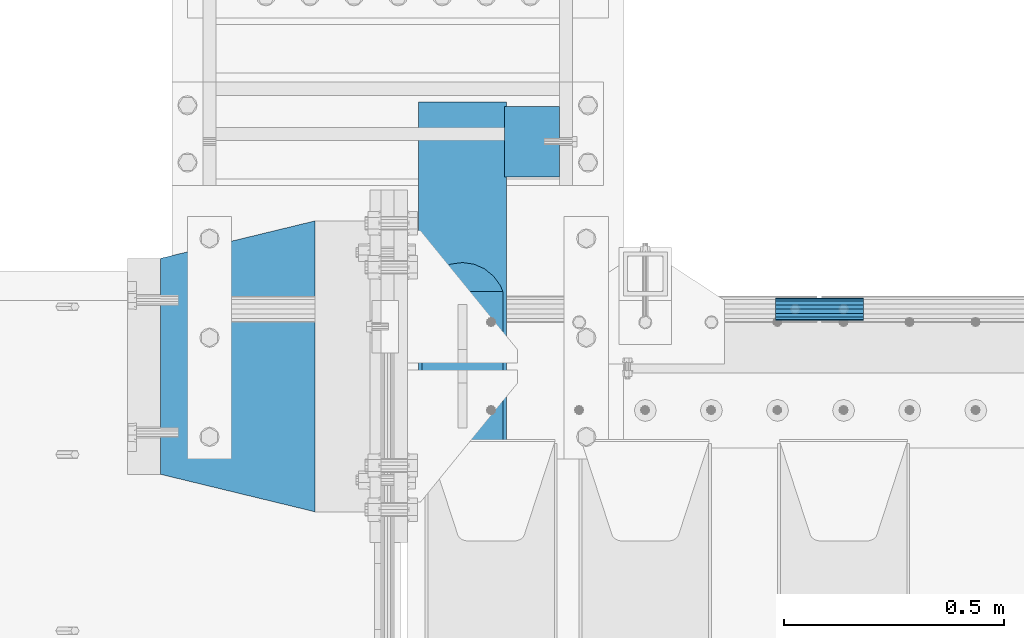
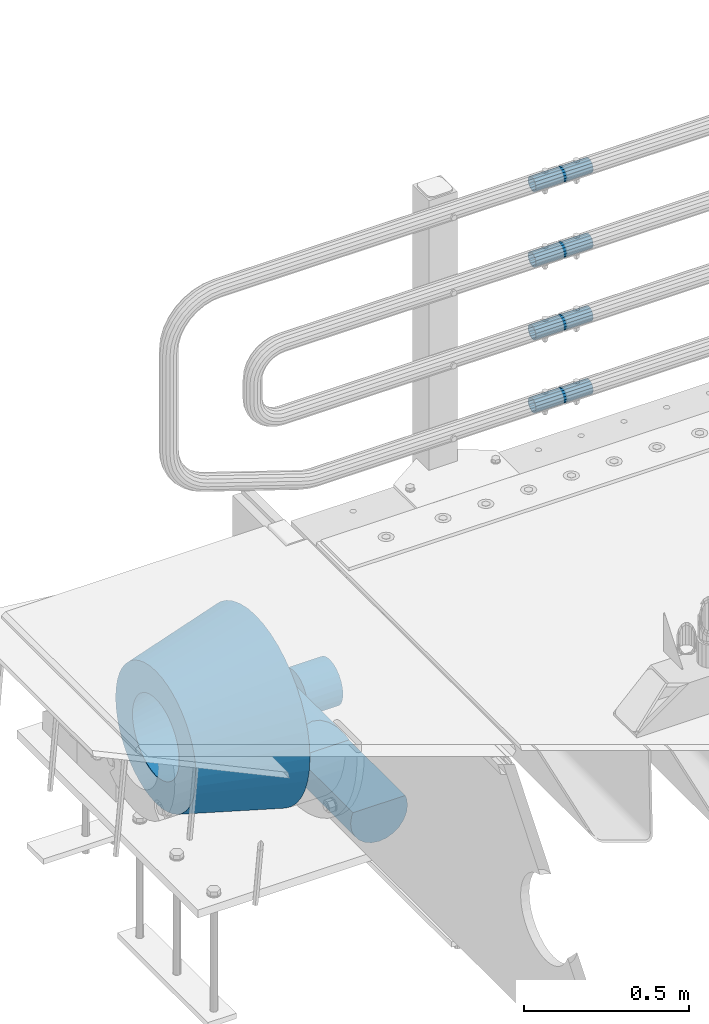
# One storey, part 146 of 242: 7 beams.
"""IFC2X3 building model written with IfcOpenShell, lengths in millimetres."""

from ifc_helpers import new_model, si_unit, frame, origin_with_axes, place, context, subcontext, project, spatial, faceted_brep, material, type_object, element, save


model = new_model("IFC2X3")

# Units and contexts
model_context = context("Model", 3, precision=1e-05, world=origin_with_axes())
body_context = subcontext(model_context, "Body", "Model", "MODEL_VIEW")
ifc_project = project(units=[si_unit("LENGTHUNIT", "METRE", prefix="MILLI"), si_unit("AREAUNIT", "SQUARE_METRE"), si_unit("VOLUMEUNIT", "CUBIC_METRE"), si_unit("MASSUNIT", "GRAM", prefix="KILO"), si_unit("TIMEUNIT", "SECOND"), si_unit("PLANEANGLEUNIT", "RADIAN"), si_unit("SOLIDANGLEUNIT", "STERADIAN"), si_unit("THERMODYNAMICTEMPERATUREUNIT", "DEGREE_CELSIUS"), si_unit("LUMINOUSINTENSITYUNIT", "LUMEN")], contexts=[model_context])

# Site, building, storey
site_placement = place(None, origin_with_axes())
site = spatial("IfcSite", under=ifc_project, at=site_placement, CompositionType="ELEMENT")
building_placement = place(site_placement, origin_with_axes())
building = spatial("IfcBuilding", under=site, at=building_placement, Name="Standard", CompositionType="ELEMENT")
storey_placement = place(building_placement, origin_with_axes())
storey = spatial("IfcBuildingStorey", under=building, at=storey_placement, Name="Undefined", CompositionType="ELEMENT", Elevation=0.0)

# Beams
ifc_material_1 = material()
beam_type_1 = type_object("IfcBeamType", PredefinedType="NOTDEFINED")
beam_1_placement = place(storey_placement, frame((-41605.0024970001, -17870.1499999996, 149.849999999726), z_axis=(0.0, 0.0, 1.0), x_axis=(1.0, 0.0, 0.0)))
element("IfcBeam", 1, at=beam_1_placement, inside=storey, type_object=beam_type_1, material=ifc_material_1, context=body_context, shape_type="Brep", body=[
    faceted_brep([(0.0, -21.9000000000015, 0.0), (0.0, -20.232961761998, 8.38076716879547), (200.0, -20.232961761998, 8.38076716879547), (200.0, -21.9000000000015, 0.0), (0.0, -15.4856385079838, 15.4856385079854), (200.0, -15.4856385079838, 15.4856385079854), (0.0, -8.38076716879368, 20.2329617619972), (200.0, -8.38076716879368, 20.2329617619972), (0.0, 0.0, 21.9), (200.0, 0.0, 21.9), (0.0, 8.38076716879368, 20.2329617619972), (200.0, 8.38076716879368, 20.2329617619972), (0.0, 15.4856385079838, 15.4856385079854), (200.0, 15.4856385079838, 15.4856385079854), (0.0, 20.232961761998, 8.38076716879547), (200.0, 20.232961761998, 8.38076716879547), (0.0, 21.9000000000015, 0.0), (200.0, 21.9000000000015, 0.0), (0.0, 20.232961761998, -8.38076716879547), (200.0, 20.232961761998, -8.38076716879547), (0.0, 15.4856385079838, -15.4856385079854), (200.0, 15.4856385079838, -15.4856385079854), (0.0, 8.38076716879368, -20.2329617619972), (200.0, 8.38076716879368, -20.2329617619972), (0.0, 0.0, -21.9), (200.0, 0.0, -21.9), (0.0, -8.38076716879368, -20.2329617619972), (200.0, -8.38076716879368, -20.2329617619972), (0.0, -15.4856385079838, -15.4856385079854), (200.0, -15.4856385079838, -15.4856385079854), (0.0, -20.232961761998, -8.38076716879547), (200.0, -20.232961761998, -8.38076716879547), (0.0, -25.5, 0.0), (0.0, -23.5589280790373, -9.7584275253098), (200.0, -23.5589280790373, -9.7584275253098), (200.0, -25.5, 0.0), (0.0, -18.0312229202573, -18.031222920257), (200.0, -18.0312229202573, -18.031222920257), (0.0, -9.75842752531025, -23.5589280790378), (200.0, -9.75842752531025, -23.5589280790378), (0.0, 0.0, -25.5), (200.0, 0.0, -25.5), (0.0, 9.75842752531025, -23.5589280790378), (200.0, 9.75842752531025, -23.5589280790378), (0.0, 18.0312229202573, -18.031222920257), (200.0, 18.0312229202573, -18.031222920257), (0.0, 23.5589280790373, -9.7584275253098), (200.0, 23.5589280790373, -9.7584275253098), (0.0, 25.5, 0.0), (200.0, 25.5, 0.0), (0.0, 23.5589280790373, 9.7584275253098), (200.0, 23.5589280790373, 9.7584275253098), (0.0, 18.0312229202573, 18.031222920257), (200.0, 18.0312229202573, 18.031222920257), (0.0, 9.75842752531025, 23.5589280790378), (200.0, 9.75842752531025, 23.5589280790378), (0.0, 0.0, 25.5), (200.0, 0.0, 25.5), (0.0, -9.75842752531025, 23.5589280790378), (200.0, -9.75842752531025, 23.5589280790378), (0.0, -18.0312229202573, 18.031222920257), (200.0, -18.0312229202573, 18.031222920257), (0.0, -23.5589280790373, 9.7584275253098), (200.0, -23.5589280790373, 9.7584275253098)], [[[0, 1, 2, 3]], [[1, 4, 5, 2]], [[4, 6, 7, 5]], [[6, 8, 9, 7]], [[8, 10, 11, 9]], [[10, 12, 13, 11]], [[12, 14, 15, 13]], [[14, 16, 17, 15]], [[16, 18, 19, 17]], [[18, 20, 21, 19]], [[20, 22, 23, 21]], [[22, 24, 25, 23]], [[24, 26, 27, 25]], [[26, 28, 29, 27]], [[28, 30, 31, 29]], [[30, 0, 3, 31]], [[32, 33, 34, 35]], [[33, 36, 37, 34]], [[36, 38, 39, 37]], [[38, 40, 41, 39]], [[40, 42, 43, 41]], [[42, 44, 45, 43]], [[44, 46, 47, 45]], [[46, 48, 49, 47]], [[48, 50, 51, 49]], [[50, 52, 53, 51]], [[52, 54, 55, 53]], [[54, 56, 57, 55]], [[56, 58, 59, 57]], [[58, 60, 61, 59]], [[60, 62, 63, 61]], [[62, 32, 35, 63]], [[37, 39, 41, 43, 45, 47, 49, 51, 53, 55, 57, 59, 61, 63, 35, 34], [5, 7, 9, 11, 13, 15, 17, 19, 21, 23, 25, 27, 29, 31, 3, 2]], [[62, 60, 58, 56, 54, 52, 50, 48, 46, 44, 42, 40, 38, 36, 33, 32], [30, 28, 26, 24, 22, 20, 18, 16, 14, 12, 10, 8, 6, 4, 1, 0]]]),
])
beam_2_placement = place(storey_placement, frame((-41605.0024970001, -17870.1499999996, 420.149999999725), z_axis=(0.0, 0.0, 1.0), x_axis=(1.0, 0.0, 0.0)))
element("IfcBeam", 2, at=beam_2_placement, inside=storey, type_object=beam_type_1, material=ifc_material_1, context=body_context, shape_type="Brep", body=[
    faceted_brep([(0.0, -21.9000000000015, 0.0), (0.0, -20.232961761998, 8.38076716879547), (200.0, -20.232961761998, 8.38076716879547), (200.0, -21.9000000000015, 0.0), (0.0, -15.4856385079838, 15.4856385079854), (200.0, -15.4856385079838, 15.4856385079854), (0.0, -8.38076716879368, 20.2329617619972), (200.0, -8.38076716879368, 20.2329617619972), (0.0, 0.0, 21.9), (200.0, 0.0, 21.9), (0.0, 8.38076716879368, 20.2329617619972), (200.0, 8.38076716879368, 20.2329617619972), (0.0, 15.4856385079838, 15.4856385079854), (200.0, 15.4856385079838, 15.4856385079854), (0.0, 20.232961761998, 8.38076716879547), (200.0, 20.232961761998, 8.38076716879547), (0.0, 21.9000000000015, 0.0), (200.0, 21.9000000000015, 0.0), (0.0, 20.232961761998, -8.38076716879547), (200.0, 20.232961761998, -8.38076716879547), (0.0, 15.4856385079838, -15.4856385079854), (200.0, 15.4856385079838, -15.4856385079854), (0.0, 8.38076716879368, -20.2329617619972), (200.0, 8.38076716879368, -20.2329617619972), (0.0, 0.0, -21.9), (200.0, 0.0, -21.9), (0.0, -8.38076716879368, -20.2329617619972), (200.0, -8.38076716879368, -20.2329617619972), (0.0, -15.4856385079838, -15.4856385079854), (200.0, -15.4856385079838, -15.4856385079854), (0.0, -20.232961761998, -8.38076716879547), (200.0, -20.232961761998, -8.38076716879547), (0.0, -25.5, 0.0), (0.0, -23.5589280790373, -9.7584275253098), (200.0, -23.5589280790373, -9.7584275253098), (200.0, -25.5, 0.0), (0.0, -18.0312229202573, -18.031222920257), (200.0, -18.0312229202573, -18.031222920257), (0.0, -9.75842752531025, -23.5589280790378), (200.0, -9.75842752531025, -23.5589280790378), (0.0, 0.0, -25.5), (200.0, 0.0, -25.5), (0.0, 9.75842752531025, -23.5589280790378), (200.0, 9.75842752531025, -23.5589280790378), (0.0, 18.0312229202573, -18.031222920257), (200.0, 18.0312229202573, -18.031222920257), (0.0, 23.5589280790373, -9.7584275253098), (200.0, 23.5589280790373, -9.7584275253098), (0.0, 25.5, 0.0), (200.0, 25.5, 0.0), (0.0, 23.5589280790373, 9.7584275253098), (200.0, 23.5589280790373, 9.7584275253098), (0.0, 18.0312229202573, 18.031222920257), (200.0, 18.0312229202573, 18.031222920257), (0.0, 9.75842752531025, 23.5589280790378), (200.0, 9.75842752531025, 23.5589280790378), (0.0, 0.0, 25.5), (200.0, 0.0, 25.5), (0.0, -9.75842752531025, 23.5589280790378), (200.0, -9.75842752531025, 23.5589280790378), (0.0, -18.0312229202573, 18.031222920257), (200.0, -18.0312229202573, 18.031222920257), (0.0, -23.5589280790373, 9.7584275253098), (200.0, -23.5589280790373, 9.7584275253098)], [[[0, 1, 2, 3]], [[1, 4, 5, 2]], [[4, 6, 7, 5]], [[6, 8, 9, 7]], [[8, 10, 11, 9]], [[10, 12, 13, 11]], [[12, 14, 15, 13]], [[14, 16, 17, 15]], [[16, 18, 19, 17]], [[18, 20, 21, 19]], [[20, 22, 23, 21]], [[22, 24, 25, 23]], [[24, 26, 27, 25]], [[26, 28, 29, 27]], [[28, 30, 31, 29]], [[30, 0, 3, 31]], [[32, 33, 34, 35]], [[33, 36, 37, 34]], [[36, 38, 39, 37]], [[38, 40, 41, 39]], [[40, 42, 43, 41]], [[42, 44, 45, 43]], [[44, 46, 47, 45]], [[46, 48, 49, 47]], [[48, 50, 51, 49]], [[50, 52, 53, 51]], [[52, 54, 55, 53]], [[54, 56, 57, 55]], [[56, 58, 59, 57]], [[58, 60, 61, 59]], [[60, 62, 63, 61]], [[62, 32, 35, 63]], [[37, 39, 41, 43, 45, 47, 49, 51, 53, 55, 57, 59, 61, 63, 35, 34], [5, 7, 9, 11, 13, 15, 17, 19, 21, 23, 25, 27, 29, 31, 3, 2]], [[62, 60, 58, 56, 54, 52, 50, 48, 46, 44, 42, 40, 38, 36, 33, 32], [30, 28, 26, 24, 22, 20, 18, 16, 14, 12, 10, 8, 6, 4, 1, 0]]]),
])
beam_3_placement = place(storey_placement, frame((-41605.0024970001, -17870.1499999996, 969.849999999726), z_axis=(0.0, 0.0, 1.0), x_axis=(1.0, 0.0, 0.0)))
element("IfcBeam", 3, at=beam_3_placement, inside=storey, type_object=beam_type_1, material=ifc_material_1, context=body_context, shape_type="Brep", body=[
    faceted_brep([(0.0, -21.9000000000015, 0.0), (0.0, -20.232961761998, 8.38076716879547), (200.0, -20.232961761998, 8.38076716879547), (200.0, -21.9000000000015, 0.0), (0.0, -15.4856385079838, 15.4856385079854), (200.0, -15.4856385079838, 15.4856385079854), (0.0, -8.38076716879368, 20.2329617619972), (200.0, -8.38076716879368, 20.2329617619972), (0.0, 0.0, 21.9), (200.0, 0.0, 21.9), (0.0, 8.38076716879368, 20.2329617619972), (200.0, 8.38076716879368, 20.2329617619972), (0.0, 15.4856385079838, 15.4856385079854), (200.0, 15.4856385079838, 15.4856385079854), (0.0, 20.232961761998, 8.38076716879547), (200.0, 20.232961761998, 8.38076716879547), (0.0, 21.9000000000015, 0.0), (200.0, 21.9000000000015, 0.0), (0.0, 20.232961761998, -8.38076716879547), (200.0, 20.232961761998, -8.38076716879547), (0.0, 15.4856385079838, -15.4856385079854), (200.0, 15.4856385079838, -15.4856385079854), (0.0, 8.38076716879368, -20.2329617619972), (200.0, 8.38076716879368, -20.2329617619972), (0.0, 0.0, -21.9), (200.0, 0.0, -21.9), (0.0, -8.38076716879368, -20.2329617619972), (200.0, -8.38076716879368, -20.2329617619972), (0.0, -15.4856385079838, -15.4856385079854), (200.0, -15.4856385079838, -15.4856385079854), (0.0, -20.232961761998, -8.38076716879547), (200.0, -20.232961761998, -8.38076716879547), (0.0, -25.5, 0.0), (0.0, -23.5589280790373, -9.7584275253098), (200.0, -23.5589280790373, -9.7584275253098), (200.0, -25.5, 0.0), (0.0, -18.0312229202573, -18.031222920257), (200.0, -18.0312229202573, -18.031222920257), (0.0, -9.75842752531025, -23.5589280790378), (200.0, -9.75842752531025, -23.5589280790378), (0.0, 0.0, -25.5), (200.0, 0.0, -25.5), (0.0, 9.75842752531025, -23.5589280790378), (200.0, 9.75842752531025, -23.5589280790378), (0.0, 18.0312229202573, -18.031222920257), (200.0, 18.0312229202573, -18.031222920257), (0.0, 23.5589280790373, -9.7584275253098), (200.0, 23.5589280790373, -9.7584275253098), (0.0, 25.5, 0.0), (200.0, 25.5, 0.0), (0.0, 23.5589280790373, 9.7584275253098), (200.0, 23.5589280790373, 9.7584275253098), (0.0, 18.0312229202573, 18.031222920257), (200.0, 18.0312229202573, 18.031222920257), (0.0, 9.75842752531025, 23.5589280790378), (200.0, 9.75842752531025, 23.5589280790378), (0.0, 0.0, 25.5), (200.0, 0.0, 25.5), (0.0, -9.75842752531025, 23.5589280790378), (200.0, -9.75842752531025, 23.5589280790378), (0.0, -18.0312229202573, 18.031222920257), (200.0, -18.0312229202573, 18.031222920257), (0.0, -23.5589280790373, 9.7584275253098), (200.0, -23.5589280790373, 9.7584275253098)], [[[0, 1, 2, 3]], [[1, 4, 5, 2]], [[4, 6, 7, 5]], [[6, 8, 9, 7]], [[8, 10, 11, 9]], [[10, 12, 13, 11]], [[12, 14, 15, 13]], [[14, 16, 17, 15]], [[16, 18, 19, 17]], [[18, 20, 21, 19]], [[20, 22, 23, 21]], [[22, 24, 25, 23]], [[24, 26, 27, 25]], [[26, 28, 29, 27]], [[28, 30, 31, 29]], [[30, 0, 3, 31]], [[32, 33, 34, 35]], [[33, 36, 37, 34]], [[36, 38, 39, 37]], [[38, 40, 41, 39]], [[40, 42, 43, 41]], [[42, 44, 45, 43]], [[44, 46, 47, 45]], [[46, 48, 49, 47]], [[48, 50, 51, 49]], [[50, 52, 53, 51]], [[52, 54, 55, 53]], [[54, 56, 57, 55]], [[56, 58, 59, 57]], [[58, 60, 61, 59]], [[60, 62, 63, 61]], [[62, 32, 35, 63]], [[37, 39, 41, 43, 45, 47, 49, 51, 53, 55, 57, 59, 61, 63, 35, 34], [5, 7, 9, 11, 13, 15, 17, 19, 21, 23, 25, 27, 29, 31, 3, 2]], [[62, 60, 58, 56, 54, 52, 50, 48, 46, 44, 42, 40, 38, 36, 33, 32], [30, 28, 26, 24, 22, 20, 18, 16, 14, 12, 10, 8, 6, 4, 1, 0]]]),
])
beam_4_placement = place(storey_placement, frame((-41605.0024970001, -17870.1499999996, 689.849999999726), z_axis=(0.0, 0.0, 1.0), x_axis=(1.0, 0.0, 0.0)))
element("IfcBeam", 4, at=beam_4_placement, inside=storey, type_object=beam_type_1, material=ifc_material_1, context=body_context, shape_type="Brep", body=[
    faceted_brep([(0.0, -21.9000000000015, 0.0), (0.0, -20.232961761998, 8.38076716879547), (200.0, -20.232961761998, 8.38076716879547), (200.0, -21.9000000000015, 0.0), (0.0, -15.4856385079838, 15.4856385079854), (200.0, -15.4856385079838, 15.4856385079854), (0.0, -8.38076716879368, 20.2329617619972), (200.0, -8.38076716879368, 20.2329617619972), (0.0, 0.0, 21.9), (200.0, 0.0, 21.9), (0.0, 8.38076716879368, 20.2329617619972), (200.0, 8.38076716879368, 20.2329617619972), (0.0, 15.4856385079838, 15.4856385079854), (200.0, 15.4856385079838, 15.4856385079854), (0.0, 20.232961761998, 8.38076716879547), (200.0, 20.232961761998, 8.38076716879547), (0.0, 21.9000000000015, 0.0), (200.0, 21.9000000000015, 0.0), (0.0, 20.232961761998, -8.38076716879547), (200.0, 20.232961761998, -8.38076716879547), (0.0, 15.4856385079838, -15.4856385079854), (200.0, 15.4856385079838, -15.4856385079854), (0.0, 8.38076716879368, -20.2329617619972), (200.0, 8.38076716879368, -20.2329617619972), (0.0, 0.0, -21.9), (200.0, 0.0, -21.9), (0.0, -8.38076716879368, -20.2329617619972), (200.0, -8.38076716879368, -20.2329617619972), (0.0, -15.4856385079838, -15.4856385079854), (200.0, -15.4856385079838, -15.4856385079854), (0.0, -20.232961761998, -8.38076716879547), (200.0, -20.232961761998, -8.38076716879547), (0.0, -25.5, 0.0), (0.0, -23.5589280790373, -9.7584275253098), (200.0, -23.5589280790373, -9.7584275253098), (200.0, -25.5, 0.0), (0.0, -18.0312229202573, -18.031222920257), (200.0, -18.0312229202573, -18.031222920257), (0.0, -9.75842752531025, -23.5589280790378), (200.0, -9.75842752531025, -23.5589280790378), (0.0, 0.0, -25.5), (200.0, 0.0, -25.5), (0.0, 9.75842752531025, -23.5589280790378), (200.0, 9.75842752531025, -23.5589280790378), (0.0, 18.0312229202573, -18.031222920257), (200.0, 18.0312229202573, -18.031222920257), (0.0, 23.5589280790373, -9.7584275253098), (200.0, 23.5589280790373, -9.7584275253098), (0.0, 25.5, 0.0), (200.0, 25.5, 0.0), (0.0, 23.5589280790373, 9.7584275253098), (200.0, 23.5589280790373, 9.7584275253098), (0.0, 18.0312229202573, 18.031222920257), (200.0, 18.0312229202573, 18.031222920257), (0.0, 9.75842752531025, 23.5589280790378), (200.0, 9.75842752531025, 23.5589280790378), (0.0, 0.0, 25.5), (200.0, 0.0, 25.5), (0.0, -9.75842752531025, 23.5589280790378), (200.0, -9.75842752531025, 23.5589280790378), (0.0, -18.0312229202573, 18.031222920257), (200.0, -18.0312229202573, 18.031222920257), (0.0, -23.5589280790373, 9.7584275253098), (200.0, -23.5589280790373, 9.7584275253098)], [[[0, 1, 2, 3]], [[1, 4, 5, 2]], [[4, 6, 7, 5]], [[6, 8, 9, 7]], [[8, 10, 11, 9]], [[10, 12, 13, 11]], [[12, 14, 15, 13]], [[14, 16, 17, 15]], [[16, 18, 19, 17]], [[18, 20, 21, 19]], [[20, 22, 23, 21]], [[22, 24, 25, 23]], [[24, 26, 27, 25]], [[26, 28, 29, 27]], [[28, 30, 31, 29]], [[30, 0, 3, 31]], [[32, 33, 34, 35]], [[33, 36, 37, 34]], [[36, 38, 39, 37]], [[38, 40, 41, 39]], [[40, 42, 43, 41]], [[42, 44, 45, 43]], [[44, 46, 47, 45]], [[46, 48, 49, 47]], [[48, 50, 51, 49]], [[50, 52, 53, 51]], [[52, 54, 55, 53]], [[54, 56, 57, 55]], [[56, 58, 59, 57]], [[58, 60, 61, 59]], [[60, 62, 63, 61]], [[62, 32, 35, 63]], [[37, 39, 41, 43, 45, 47, 49, 51, 53, 55, 57, 59, 61, 63, 35, 34], [5, 7, 9, 11, 13, 15, 17, 19, 21, 23, 25, 27, 29, 31, 3, 2]], [[62, 60, 58, 56, 54, 52, 50, 48, 46, 44, 42, 40, 38, 36, 33, 32], [30, 28, 26, 24, 22, 20, 18, 16, 14, 12, 10, 8, 6, 4, 1, 0]]]),
])
ifc_material_2 = material(Name="STEEL/S355N")
beam_type_2 = type_object("IfcBeamType", Name="D200", PredefinedType="NOTDEFINED")
beam_5_placement = place(storey_placement, frame((-42315.0, -17400.0, -938.0), z_axis=(0.0, 0.0, 1.0), x_axis=(0.0, -1.0, 0.0)))
element("IfcBeam", 5, at=beam_5_placement, inside=storey, type_object=beam_type_2, material=ifc_material_2, ObjectType="D200", context=body_context, shape_type="Brep", body=[
    faceted_brep([(430.0, 91.5731031269243, 38.0), (430.0, -91.5731031269243, 38.0), (770.0, -91.5731031269243, 37.9999999999994), (770.0, 91.5731031269243, 37.9999999999994), (417.294117647056, 86.6025403784442, 50.0), (395.365164344952, 70.7106781186521, 70.7106781186548), (378.538486658119, 50.0, 86.6025403784439), (367.960794863509, 25.88190451025, 96.5925826289068), (364.352941176468, 0.0, 100.0), (367.960794863509, -25.88190451025, 96.5925826289068), (378.538486658119, -50.0, 86.6025403784439), (395.365164344952, -70.7106781186521, 70.7106781186548), (417.294117647056, -86.6025403784442, 50.0), (0.0, -96.5925826289094, 25.8819045102521), (0.0, -100.0, 0.0), (770.0, -100.0, 0.0), (770.0, -96.5925826289094, 25.8819045102521), (0.0, 96.5925826289094, -25.8819045102521), (0.0, 100.0, 0.0), (770.0, 100.0, 0.0), (770.0, 96.5925826289094, -25.8819045102521), (0.0, 86.6025403784442, -50.0), (770.0, 86.6025403784442, -50.0), (0.0, 70.7106781186521, -70.7106781186548), (770.0, 70.7106781186521, -70.7106781186548), (0.0, 50.0, -86.6025403784438), (770.0, 50.0, -86.6025403784438), (0.0, 25.88190451025, -96.5925826289067), (770.0, 25.88190451025, -96.5925826289067), (0.0, 0.0, -100.0), (770.0, 0.0, -100.0), (0.0, -25.88190451025, -96.5925826289069), (770.0, -25.88190451025, -96.5925826289069), (0.0, -50.0, -86.6025403784438), (770.0, -50.0, -86.6025403784438), (0.0, -70.7106781186521, -70.7106781186548), (770.0, -70.7106781186521, -70.7106781186548), (0.0, -86.6025403784442, -50.0), (770.0, -86.6025403784442, -50.0), (0.0, -96.5925826289094, -25.8819045102522), (770.0, -96.5925826289094, -25.8819045102522), (0.0, -86.6025403784442, 50.0), (0.0, -70.7106781186521, 70.7106781186548), (0.0, -50.0, 86.6025403784439), (0.0, -25.88190451025, 96.5925826289068), (0.0, 0.0, 100.0), (0.0, 25.88190451025, 96.5925826289068), (0.0, 50.0, 86.6025403784439), (0.0, 70.7106781186521, 70.7106781186548), (0.0, 86.6025403784442, 50.0), (0.0, 96.5925826289094, 25.8819045102521), (770.0, 96.5925826289094, 25.8819045102521)], [[[0, 1, 2, 3]], [[4, 5, 6, 7, 8, 9, 10, 11, 12, 1, 0]], [[13, 14, 15, 16]], [[17, 18, 19, 20]], [[21, 17, 20, 22]], [[23, 21, 22, 24]], [[25, 23, 24, 26]], [[27, 25, 26, 28]], [[29, 27, 28, 30]], [[31, 29, 30, 32]], [[33, 31, 32, 34]], [[35, 33, 34, 36]], [[37, 35, 36, 38]], [[39, 37, 38, 40]], [[14, 39, 40, 15]], [[13, 41, 42, 43, 44, 45, 46, 47, 48, 49, 50, 18, 17, 21, 23, 25, 27, 29, 31, 33, 35, 37, 39, 14]], [[18, 50, 51, 19]], [[16, 15, 40, 38, 36, 34, 32, 30, 28, 26, 24, 22, 20, 19, 51, 3, 2]], [[41, 13, 16, 2, 1, 12]], [[42, 41, 12, 11]], [[43, 42, 11, 10]], [[44, 43, 10, 9]], [[45, 44, 9, 8]], [[46, 45, 8, 7]], [[47, 46, 7, 6]], [[48, 47, 6, 5]], [[49, 48, 5, 4]], [[51, 50, 49, 4, 0, 3]]]),
])
ifc_material_3 = material(Name="SCN-500-E2")
beam_type_3 = type_object("IfcBeamType", PredefinedType="NOTDEFINED")
beam_6_placement = place(storey_placement, frame((-42650.0, -18000.0, -515.0), z_axis=(0.0, 0.0, 1.0), x_axis=(-1.0, 0.0, 0.0)))
element("IfcBeam", 6, at=beam_6_placement, inside=storey, type_object=beam_type_3, material=ifc_material_3, context=body_context, shape_type="Brep", body=[
    faceted_brep([(0.0, -330.0, 0.0), (0.0, -326.641075820709, -46.9638966301842), (350.0, -242.506253260828, -34.8671353769549), (350.0, -245.0, 0.0), (0.0, -316.632681292784, -92.9717437576718), (350.0, -235.075778535553, -69.0244764261503), (0.0, -300.178558466992, -137.086954290623), (350.0, -222.859838861856, -101.776678185462), (0.0, -277.613665834291, -178.411469760347), (350.0, -206.10711554364, -132.457000276621), (0.0, -249.397359536906, -216.104042201944), (350.0, -185.158645716794, -160.440879816595), (0.0, -216.104042201943, -249.397359536905), (350.0, -160.440879816593, -185.158645716793), (0.0, -178.411469760347, -277.61366583429), (350.0, -132.45700027662, -206.107115543639), (0.0, -137.086954290622, -300.178558466991), (350.0, -101.776678185463, -222.859838861857), (0.0, -92.9717437576728, -316.632681292784), (350.0, -69.0244764261515, -235.075778535552), (0.0, -46.9638966301827, -326.641075820708), (350.0, -34.8671353769532, -242.506253260829), (0.0, 0.0, -330.0), (350.0, 0.0, -245.0), (0.0, 46.9638966301827, -326.641075820708), (350.0, 34.8671353769532, -242.506253260829), (0.0, 92.9717437576728, -316.632681292784), (350.0, 69.0244764261515, -235.075778535552), (0.0, 137.086954290622, -300.178558466991), (350.0, 101.776678185463, -222.859838861857), (0.0, 178.411469760347, -277.61366583429), (350.0, 132.457000276623, -206.107115543639), (0.0, 216.104042201943, -249.397359536905), (350.0, 160.440879816593, -185.158645716793), (0.0, 249.397359536906, -216.104042201944), (350.0, 185.158645716794, -160.440879816595), (0.0, 277.613665834291, -178.411469760347), (350.0, 206.10711554364, -132.457000276621), (0.0, 300.178558466992, -137.086954290623), (350.0, 222.859838861856, -101.776678185462), (0.0, 316.632681292784, -92.9717437576717), (350.0, 235.075778535553, -69.0244764261502), (0.0, 326.641075820709, -46.9638966301841), (350.0, 242.506253260828, -34.8671353769548), (0.0, 330.0, 0.0), (350.0, 245.0, 0.0), (0.0, 326.641075820709, 46.9638966301841), (350.0, 242.506253260828, 34.8671353769549), (0.0, 316.632681292784, 92.9717437576718), (350.0, 235.075778535553, 69.0244764261503), (0.0, 300.178558466992, 137.086954290622), (350.0, 222.859838861856, 101.776678185462), (0.0, 277.613665834291, 178.411469760347), (350.0, 206.10711554364, 132.457000276621), (0.0, 249.397359536906, 216.104042201944), (350.0, 185.158645716794, 160.440879816595), (0.0, 216.104042201943, 249.397359536905), (350.0, 160.440879816593, 185.158645716793), (0.0, 178.411469760347, 277.61366583429), (350.0, 132.457000276623, 206.107115543639), (0.0, 137.086954290622, 300.178558466991), (350.0, 101.776678185463, 222.859838861857), (0.0, 92.9717437576728, 316.632681292784), (350.0, 69.0244764261515, 235.075778535552), (0.0, 46.9638966301827, 326.641075820708), (350.0, 34.8671353769532, 242.506253260829), (0.0, 0.0, 330.0), (350.0, 0.0, 245.0), (0.0, -46.9638966301827, 326.641075820708), (350.0, -34.8671353769532, 242.506253260829), (0.0, -92.9717437576728, 316.632681292784), (350.0, -69.0244764261515, 235.075778535552), (0.0, -137.086954290622, 300.178558466991), (350.0, -101.776678185463, 222.859838861857), (0.0, -178.411469760347, 277.61366583429), (350.0, -132.457000276623, 206.107115543639), (0.0, -216.104042201943, 249.397359536905), (350.0, -160.440879816593, 185.158645716793), (0.0, -249.397359536906, 216.104042201944), (350.0, -185.158645716794, 160.440879816595), (0.0, -277.613665834291, 178.411469760347), (350.0, -206.10711554364, 132.457000276621), (0.0, -300.178558466992, 137.086954290623), (350.0, -222.859838861856, 101.776678185462), (0.0, -316.632681292784, 92.9717437576718), (350.0, -235.075778535553, 69.0244764261503), (0.0, -326.641075820709, 46.9638966301841), (350.0, -242.506253260828, 34.8671353769549), (0.0, -227.093265923133, 0.0), (0.0, -224.781783917482, 32.3187414128026), (350.0, -140.646961357605, 20.2219801595734), (350.0, -142.093265923133, 0.0), (0.0, -217.894393008413, 63.9795664499945), (350.0, -136.337490251182, 40.032299118473), (0.0, -206.571300613232, 94.3379520160985), (350.0, -129.252581008099, 59.0276759109381), (0.0, -191.043012240007, 122.775888927343), (350.0, -119.536461949356, 76.8214194436173), (0.0, -171.625639060127, 148.714462796454), (350.0, -107.386925240015, 93.0513004111044), (0.0, -148.714462796455, 171.625639060125), (350.0, -93.0513004111053, 107.386925240013), (0.0, -122.775888927343, 191.043012240005), (350.0, -76.8214194436187, 119.536461949355), (0.0, -94.3379520160997, 206.571300613232), (350.0, -59.0276759109365, 129.252581008098), (0.0, -63.9795664499943, 217.894393008413), (350.0, -40.032299118473, 136.337490251181), (0.0, -32.3187414128042, 224.781783917484), (350.0, -20.2219801595747, 140.646961357605), (0.0, 0.0, 227.093265923131), (350.0, 0.0, 142.093265923131), (0.0, 32.3187414128042, 224.781783917484), (350.0, 20.2219801595747, 140.646961357605), (0.0, 63.9795664499943, 217.894393008413), (350.0, 40.032299118473, 136.337490251181), (0.0, 94.3379520160997, 206.571300613232), (350.0, 59.0276759109365, 129.252581008098), (0.0, 122.775888927343, 191.043012240005), (350.0, 76.8214194436187, 119.536461949355), (0.0, 148.714462796455, 171.625639060125), (350.0, 93.0513004111053, 107.386925240013), (0.0, 171.625639060127, 148.714462796454), (350.0, 107.386925240015, 93.0513004111044), (0.0, 191.043012240007, 122.775888927343), (350.0, 119.536461949356, 76.8214194436174), (0.0, 206.571300613232, 94.3379520160985), (350.0, 129.252581008099, 59.0276759109382), (0.0, 217.894393008413, 63.9795664499945), (350.0, 136.337490251182, 40.032299118473), (0.0, 224.781783917482, 32.3187414128025), (350.0, 140.646961357605, 20.2219801595733), (0.0, 227.093265923133, 0.0), (350.0, 142.093265923133, 0.0), (0.0, 224.781783917482, -32.3187414128026), (350.0, 140.646961357605, -20.2219801595734), (0.0, 217.894393008413, -63.9795664499945), (350.0, 136.337490251182, -40.032299118473), (0.0, 206.571300613232, -94.3379520160985), (350.0, 129.252581008099, -59.0276759109381), (0.0, 191.043012240007, -122.775888927343), (350.0, 119.536461949356, -76.8214194436174), (0.0, 171.625639060127, -148.714462796454), (350.0, 107.386925240015, -93.0513004111044), (0.0, 148.714462796455, -171.625639060125), (350.0, 93.0513004111053, -107.386925240013), (0.0, 122.775888927343, -191.043012240005), (350.0, 76.8214194436187, -119.536461949355), (0.0, 94.3379520160997, -206.571300613232), (350.0, 59.0276759109365, -129.252581008098), (0.0, 63.9795664499943, -217.894393008413), (350.0, 40.032299118473, -136.337490251181), (0.0, 32.3187414128042, -224.781783917484), (350.0, 20.2219801595747, -140.646961357605), (0.0, 0.0, -227.093265923131), (350.0, 0.0, -142.093265923131), (0.0, -32.3187414128042, -224.781783917484), (350.0, -20.2219801595747, -140.646961357605), (0.0, -63.9795664499943, -217.894393008413), (350.0, -40.032299118473, -136.337490251181), (0.0, -94.3379520160997, -206.571300613232), (350.0, -59.0276759109365, -129.252581008098), (0.0, -122.775888927343, -191.043012240005), (350.0, -76.8214194436187, -119.536461949355), (0.0, -148.714462796455, -171.625639060125), (350.0, -93.0513004111053, -107.386925240013), (0.0, -171.625639060127, -148.714462796454), (350.0, -107.386925240015, -93.0513004111044), (0.0, -191.043012240007, -122.775888927343), (350.0, -119.536461949356, -76.8214194436174), (0.0, -206.571300613232, -94.3379520160985), (350.0, -129.252581008099, -59.0276759109381), (0.0, -217.894393008413, -63.9795664499945), (350.0, -136.337490251182, -40.032299118473), (0.0, -224.781783917482, -32.3187414128026), (350.0, -140.646961357605, -20.2219801595734)], [[[0, 1, 2, 3]], [[1, 4, 5, 2]], [[4, 6, 7, 5]], [[6, 8, 9, 7]], [[8, 10, 11, 9]], [[10, 12, 13, 11]], [[12, 14, 15, 13]], [[14, 16, 17, 15]], [[16, 18, 19, 17]], [[18, 20, 21, 19]], [[20, 22, 23, 21]], [[22, 24, 25, 23]], [[24, 26, 27, 25]], [[26, 28, 29, 27]], [[28, 30, 31, 29]], [[30, 32, 33, 31]], [[32, 34, 35, 33]], [[34, 36, 37, 35]], [[36, 38, 39, 37]], [[38, 40, 41, 39]], [[40, 42, 43, 41]], [[42, 44, 45, 43]], [[44, 46, 47, 45]], [[46, 48, 49, 47]], [[48, 50, 51, 49]], [[50, 52, 53, 51]], [[52, 54, 55, 53]], [[54, 56, 57, 55]], [[56, 58, 59, 57]], [[58, 60, 61, 59]], [[60, 62, 63, 61]], [[62, 64, 65, 63]], [[64, 66, 67, 65]], [[66, 68, 69, 67]], [[68, 70, 71, 69]], [[70, 72, 73, 71]], [[72, 74, 75, 73]], [[74, 76, 77, 75]], [[76, 78, 79, 77]], [[78, 80, 81, 79]], [[80, 82, 83, 81]], [[82, 84, 85, 83]], [[84, 86, 87, 85]], [[86, 0, 3, 87]], [[88, 89, 90, 91]], [[89, 92, 93, 90]], [[92, 94, 95, 93]], [[94, 96, 97, 95]], [[96, 98, 99, 97]], [[98, 100, 101, 99]], [[100, 102, 103, 101]], [[102, 104, 105, 103]], [[104, 106, 107, 105]], [[106, 108, 109, 107]], [[108, 110, 111, 109]], [[110, 112, 113, 111]], [[112, 114, 115, 113]], [[114, 116, 117, 115]], [[116, 118, 119, 117]], [[118, 120, 121, 119]], [[120, 122, 123, 121]], [[122, 124, 125, 123]], [[124, 126, 127, 125]], [[126, 128, 129, 127]], [[128, 130, 131, 129]], [[130, 132, 133, 131]], [[132, 134, 135, 133]], [[134, 136, 137, 135]], [[136, 138, 139, 137]], [[138, 140, 141, 139]], [[140, 142, 143, 141]], [[142, 144, 145, 143]], [[144, 146, 147, 145]], [[146, 148, 149, 147]], [[148, 150, 151, 149]], [[150, 152, 153, 151]], [[152, 154, 155, 153]], [[154, 156, 157, 155]], [[156, 158, 159, 157]], [[158, 160, 161, 159]], [[160, 162, 163, 161]], [[162, 164, 165, 163]], [[164, 166, 167, 165]], [[166, 168, 169, 167]], [[168, 170, 171, 169]], [[170, 172, 173, 171]], [[172, 174, 175, 173]], [[174, 88, 91, 175]], [[5, 7, 9, 11, 13, 15, 17, 19, 21, 23, 25, 27, 29, 31, 33, 35, 37, 39, 41, 43, 45, 47, 49, 51, 53, 55, 57, 59, 61, 63, 65, 67, 69, 71, 73, 75, 77, 79, 81, 83, 85, 87, 3, 2], [93, 95, 97, 99, 101, 103, 105, 107, 109, 111, 113, 115, 117, 119, 121, 123, 125, 127, 129, 131, 133, 135, 137, 139, 141, 143, 145, 147, 149, 151, 153, 155, 157, 159, 161, 163, 165, 167, 169, 171, 173, 175, 91, 90]], [[86, 84, 82, 80, 78, 76, 74, 72, 70, 68, 66, 64, 62, 60, 58, 56, 54, 52, 50, 48, 46, 44, 42, 40, 38, 36, 34, 32, 30, 28, 26, 24, 22, 20, 18, 16, 14, 12, 10, 8, 6, 4, 1, 0], [174, 172, 170, 168, 166, 164, 162, 160, 158, 156, 154, 152, 150, 148, 146, 144, 142, 140, 138, 136, 134, 132, 130, 128, 126, 124, 122, 120, 118, 116, 114, 112, 110, 108, 106, 104, 102, 100, 98, 96, 94, 92, 89, 88]]]),
])
ifc_material_4 = material()
beam_type_4 = type_object("IfcBeamType", PredefinedType="NOTDEFINED")
beam_7_placement = place(storey_placement, frame((-42220.0000000012, -17490.0000000031, -933.000000000004), z_axis=(0.0, 0.0, 1.0), x_axis=(1.0, 0.0, 0.0)))
element("IfcBeam", 7, at=beam_7_placement, inside=storey, type_object=beam_type_4, material=ifc_material_4, context=body_context, shape_type="Brep", body=[
    faceted_brep([(0.0, -80.0000000000036, 0.0), (0.0, -77.2740661031312, -20.7055236082015), (125.0, -77.2740661031239, -20.7055236082017), (125.0, -80.0, 0.0), (-9.09494701772928e-13, -69.2820323027554, -40.0), (125.0, -69.2820323027554, -40.0), (-1.81898940354586e-12, -56.5685424949297, -56.5685424949224), (125.0, -56.5685424949224, -56.5685424949238), (0.0, -40.0000000000036, -69.2820323027554), (125.0, -40.0, -69.2820323027552), (-9.09494701772928e-13, -20.7055236082015, -77.2740661031239), (125.0, -20.7055236082015, -77.2740661031255), (-9.09494701772928e-13, -3.63797880709171e-12, -80.0), (125.0, 0.0, -80.0), (0.0, 20.7055236081978, -77.2740661031239), (125.0, 20.7055236082015, -77.2740661031255), (-9.09494701772928e-13, 39.9999999999927, -69.2820323027554), (125.0, 40.0, -69.2820323027551), (0.0, 56.5685424949188, -56.5685424949224), (125.0, 56.5685424949224, -56.5685424949238), (-9.09494701772928e-13, 69.2820323027518, -40.0), (125.0, 69.2820323027554, -40.0), (-1.81898940354586e-12, 77.2740661031203, -20.7055236082015), (125.0, 77.2740661031239, -20.7055236082016), (-1.81898940354586e-12, 79.9999999999964, 0.0), (125.0, 80.0, 0.0), (-1.81898940354586e-12, 77.2740661031203, 20.7055236082015), (125.0, 77.2740661031239, 20.7055236082017), (-9.09494701772928e-13, 69.2820323027518, 40.0), (125.0, 69.2820323027554, 40.0), (0.0, 56.5685424949188, 56.5685424949224), (125.0, 56.5685424949224, 56.5685424949238), (-9.09494701772928e-13, 39.9999999999927, 69.2820323027554), (125.0, 40.0, 69.2820323027551), (0.0, 20.7055236081978, 77.2740661031239), (125.0, 20.7055236082015, 77.2740661031255), (-9.09494701772928e-13, -3.63797880709171e-12, 80.0), (125.0, 0.0, 80.0), (-9.09494701772928e-13, -20.7055236082015, 77.2740661031239), (125.0, -20.7055236082015, 77.2740661031255), (0.0, -40.0000000000036, 69.2820323027554), (125.0, -40.0, 69.2820323027551), (-1.81898940354586e-12, -56.5685424949297, 56.5685424949224), (125.0, -56.5685424949224, 56.5685424949238), (-9.09494701772928e-13, -69.2820323027554, 40.0), (125.0, -69.2820323027554, 40.0), (0.0, -77.2740661031312, 20.7055236082015), (125.0, -77.2740661031239, 20.7055236082017)], [[[0, 1, 2, 3]], [[1, 4, 5, 2]], [[4, 6, 7, 5]], [[6, 8, 9, 7]], [[8, 10, 11, 9]], [[10, 12, 13, 11]], [[12, 14, 15, 13]], [[14, 16, 17, 15]], [[16, 18, 19, 17]], [[18, 20, 21, 19]], [[20, 22, 23, 21]], [[22, 24, 25, 23]], [[24, 26, 27, 25]], [[26, 28, 29, 27]], [[28, 30, 31, 29]], [[30, 32, 33, 31]], [[32, 34, 35, 33]], [[34, 36, 37, 35]], [[36, 38, 39, 37]], [[38, 40, 41, 39]], [[40, 42, 43, 41]], [[42, 44, 45, 43]], [[44, 46, 47, 45]], [[46, 0, 3, 47]], [[5, 7, 9, 11, 13, 15, 17, 19, 21, 23, 25, 27, 29, 31, 33, 35, 37, 39, 41, 43, 45, 47, 3, 2]], [[46, 44, 42, 40, 38, 36, 34, 32, 30, 28, 26, 24, 22, 20, 18, 16, 14, 12, 10, 8, 6, 4, 1, 0]]]),
])

save(model, "model.ifc")
